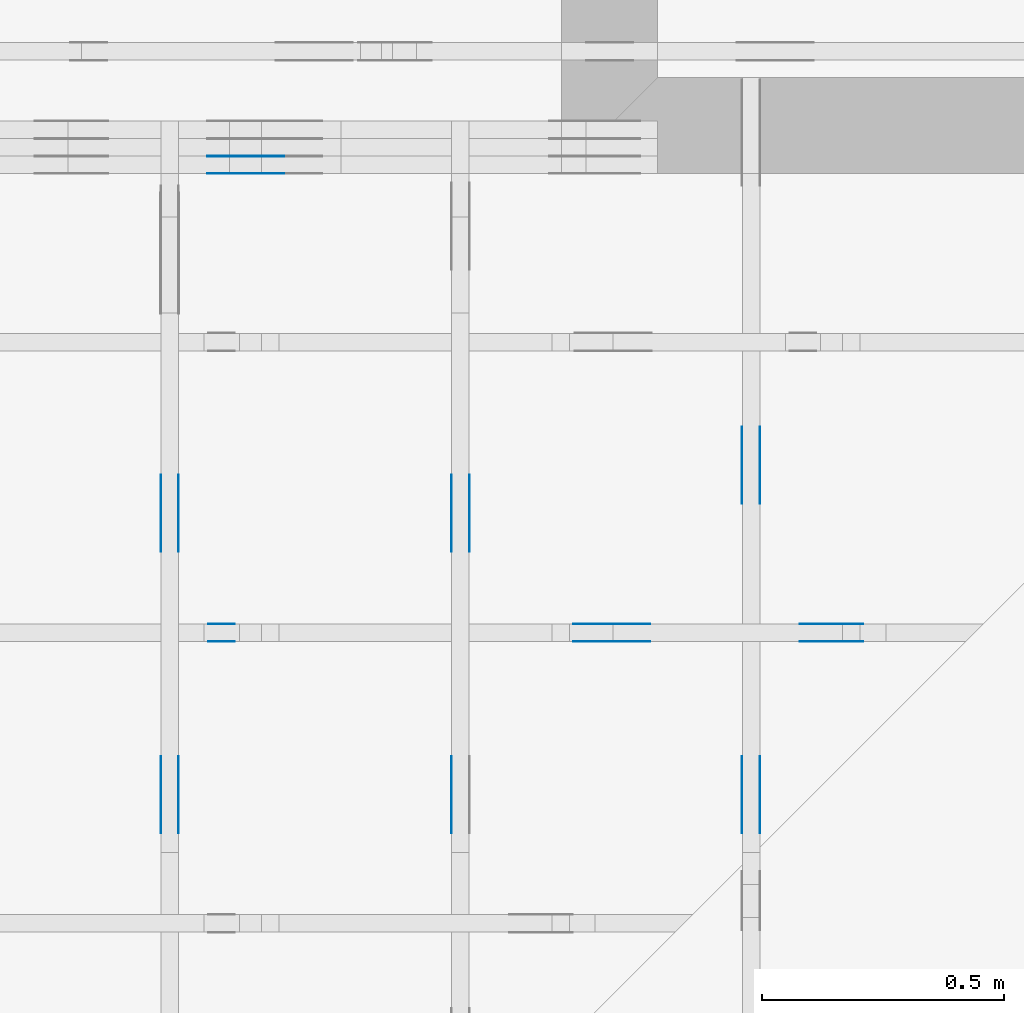
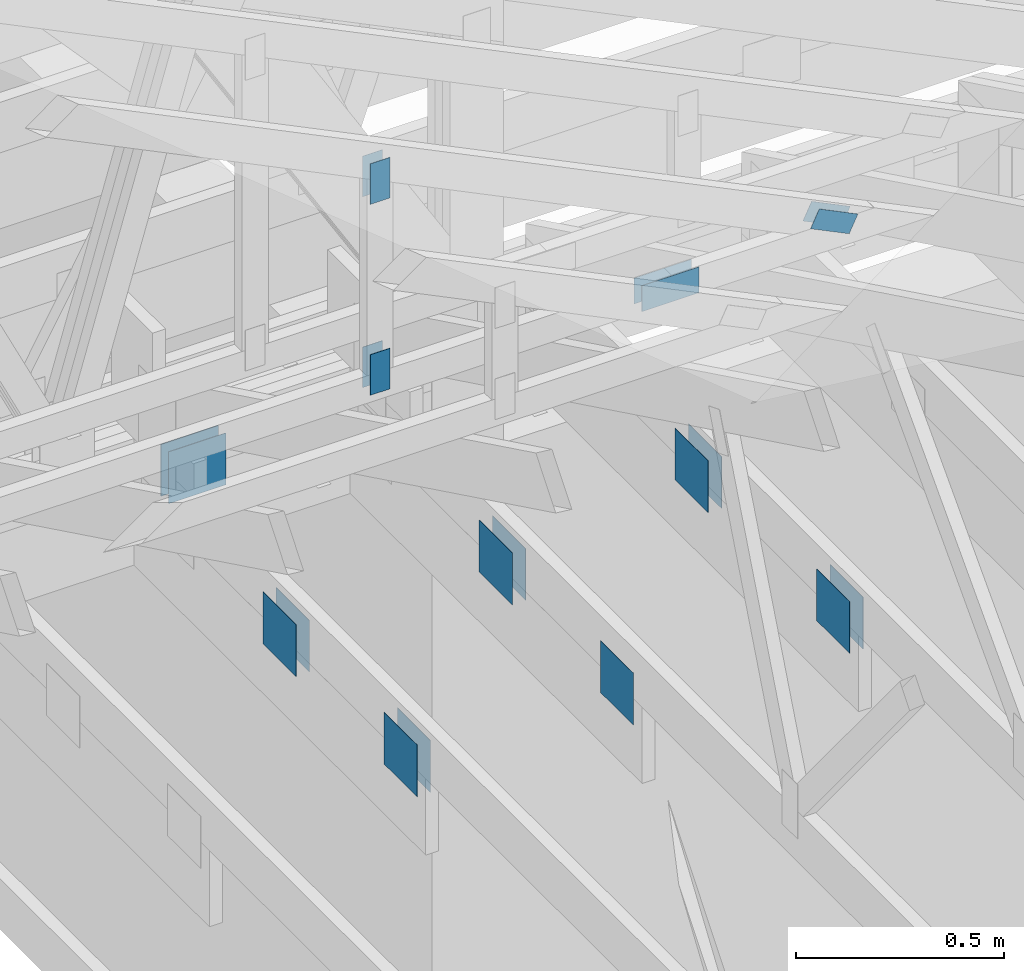
# One storey, part 126 of 159: 22 plates, 5 elements without a shape of their own.
"""IFC2X3 building model written with IfcOpenShell, lengths in millimetres."""

from ifc_helpers import new_model, si_unit, frame, origin, origin_with_axes, origin_2d, place, context, project, spatial, faceted_brep, element, aggregate, save


model = new_model("IFC2X3")

# Units and contexts
model_context = context("Model", 3, precision=1e-05, world=origin())
plan_context = context("Plan", 2, precision=1e-05, world=origin_2d())
ifc_project = project(units=[si_unit("LENGTHUNIT", "METRE", prefix="MILLI"), si_unit("AREAUNIT", "SQUARE_METRE"), si_unit("VOLUMEUNIT", "CUBIC_METRE"), si_unit("SOLIDANGLEUNIT", "STERADIAN"), si_unit("PLANEANGLEUNIT", "RADIAN"), si_unit("MASSUNIT", "GRAM"), si_unit("TIMEUNIT", "SECOND"), si_unit("THERMODYNAMICTEMPERATUREUNIT", "DEGREE_CELSIUS"), si_unit("LUMINOUSINTENSITYUNIT", "LUMEN")], contexts=[model_context, plan_context])

# Site, building, storey
site_placement = place(None, origin_with_axes())
site = spatial("IfcSite", under=ifc_project, at=site_placement, CompositionType="ELEMENT")
building_placement = place(site_placement, origin_with_axes())
building = spatial("IfcBuilding", under=site, at=building_placement, Name="Plan 1", CompositionType="ELEMENT")
storey_placement = place(building_placement, origin_with_axes())
storey = spatial("IfcBuildingStorey", under=building, at=storey_placement, Name="Etasje 1", CompositionType="ELEMENT", Elevation=0.0)

# Assembly, plates
assembly_1_placement = place(storey_placement, frame((10700.012663101485, 8801.999999990367, 0.0), z_axis=(0.0, -1.0, 6.123031769111886e-17), x_axis=(1.0, 0.0, 0.0)))
assembly_1 = element("IfcElementAssembly", 1, at=assembly_1_placement, inside=storey, Name="T8 (1)", AssemblyPlace="FACTORY", PredefinedType="TRUSS")
plate_1_placement = place(assembly_1_placement, frame((5070.5, 146.99999999999977, 0.0), z_axis=(0.0, 0.0, 1.0), x_axis=(1.0, 0.0, 0.0)))
plate_1 = element("IfcPlate", 2, at=plate_1_placement, Name="GNT100S 152x159", context=model_context, shape_type="Brep", body=[
    faceted_brep([(159.0, 152.00000000000023, 1.0), (0.0, 152.00000000000023, 1.0), (0.0, 2.2737367544323206e-13, 1.0), (159.0, 2.2737367544323206e-13, 1.0), (0.0, 152.00000000000023, 0.0), (159.0, 152.00000000000023, 1.9471241025775798e-14), (159.0, 2.2737367544323206e-13, 1.9471241025775798e-14), (0.0, 2.2737367544323206e-13, 0.0), (159.0, -2.92068615386637e-14, 1.788345410772899e-30), (159.0, -2.914563122097258e-14, 1.0), (1.1247455413666031e-32, 6.123031769111886e-17, 1.0), (0.0, 0.0, 0.0), (159.0, 152.0, 0.0), (159.0, 152.0, 1.0), (159.0, 0.0, 1.0), (159.0, 0.0, 0.0), (0.0, 152.0, 0.0), (-3.7491518045553436e-33, 152.0, 1.0), (159.0, 152.0, 1.0), (159.0, 152.0, 0.0), (0.0, 0.0, 0.0), (6.123031769111886e-17, -7.498303609110687e-33, 1.0), (1.8675246895791253e-14, 152.0, 1.0), (1.8614016578100134e-14, 152.0, -1.1397421485848245e-30)], [[[0, 1, 2, 3]], [[4, 5, 6, 7]], [[8, 9, 10, 11]], [[12, 13, 14, 15]], [[16, 17, 18, 19]], [[20, 21, 22, 23]]]),
])
plate_2_placement = place(assembly_1_placement, frame((5070.5, 146.99999999999977, -37.0), z_axis=(0.0, 0.0, 1.0), x_axis=(1.0, 0.0, 0.0)))
plate_2 = element("IfcPlate", 3, at=plate_2_placement, Name="GNT100S 152x159", context=model_context, shape_type="Brep", body=[
    faceted_brep([(159.0, 152.00000000000023, 1.0), (0.0, 152.00000000000023, 1.0), (0.0, 2.2737367544323206e-13, 1.0), (159.0, 2.2737367544323206e-13, 1.0), (0.0, 152.00000000000023, 0.0), (159.0, 152.00000000000023, 1.9471241025775798e-14), (159.0, 2.2737367544323206e-13, 1.9471241025775798e-14), (0.0, 2.2737367544323206e-13, 0.0), (159.0, -2.92068615386637e-14, 1.788345410772899e-30), (159.0, -2.914563122097258e-14, 1.0), (1.1247455413666031e-32, 6.123031769111886e-17, 1.0), (0.0, 0.0, 0.0), (159.0, 152.0, 0.0), (159.0, 152.0, 1.0), (159.0, 0.0, 1.0), (159.0, 0.0, 0.0), (0.0, 152.0, 0.0), (-3.7491518045553436e-33, 152.0, 1.0), (159.0, 152.0, 1.0), (159.0, 152.0, 0.0), (0.0, 0.0, 0.0), (6.123031769111886e-17, -7.498303609110687e-33, 1.0), (1.8675246895791253e-14, 152.0, 1.0), (1.8614016578100134e-14, 152.0, -1.1397421485848245e-30)], [[[0, 1, 2, 3]], [[4, 5, 6, 7]], [[8, 9, 10, 11]], [[12, 13, 14, 15]], [[16, 17, 18, 19]], [[20, 21, 22, 23]]]),
])
plate_3_placement = place(assembly_1_placement, frame((5070.5, 146.99999999999977, -36.0), z_axis=(0.0, 0.0, 1.0), x_axis=(1.0, 0.0, 0.0)))
plate_3 = element("IfcPlate", 4, at=plate_3_placement, Name="GNT100S 152x159", context=model_context, shape_type="Brep", body=[
    faceted_brep([(159.0, 152.00000000000023, 1.0), (0.0, 152.00000000000023, 1.0), (0.0, 2.2737367544323206e-13, 1.0), (159.0, 2.2737367544323206e-13, 1.0), (0.0, 152.00000000000023, 0.0), (159.0, 152.00000000000023, 1.9471241025775798e-14), (159.0, 2.2737367544323206e-13, 1.9471241025775798e-14), (0.0, 2.2737367544323206e-13, 0.0), (159.0, -2.92068615386637e-14, 1.788345410772899e-30), (159.0, -2.914563122097258e-14, 1.0), (1.1247455413666031e-32, 6.123031769111886e-17, 1.0), (0.0, 0.0, 0.0), (159.0, 152.0, 0.0), (159.0, 152.0, 1.0), (159.0, 0.0, 1.0), (159.0, 0.0, 0.0), (0.0, 152.0, 0.0), (-3.7491518045553436e-33, 152.0, 1.0), (159.0, 152.0, 1.0), (159.0, 152.0, 0.0), (0.0, 0.0, 0.0), (6.123031769111886e-17, -7.498303609110687e-33, 1.0), (1.8675246895791253e-14, 152.0, 1.0), (1.8614016578100134e-14, 152.0, -1.1397421485848245e-30)], [[[0, 1, 2, 3]], [[4, 5, 6, 7]], [[8, 9, 10, 11]], [[12, 13, 14, 15]], [[16, 17, 18, 19]], [[20, 21, 22, 23]]]),
])
aggregate(assembly_1, [plate_1, plate_2, plate_3])

assembly_2_placement = place(storey_placement, frame((16311.022261404749, -699.9989301294839, 1.1021457184401395e-15), z_axis=(1.0, -6.123031769111886e-17, 6.123031769111886e-17), x_axis=(6.123031769111886e-17, 1.0, 0.0)))
assembly_2 = element("IfcElementAssembly", 5, at=assembly_2_placement, inside=storey, Name="V8 (33)", AssemblyPlace="FACTORY", PredefinedType="TRUSS")
plate_4_placement = place(assembly_2_placement, frame((8139.998930119909, 147.0, -37.0), z_axis=(0.0, 0.0, 1.0), x_axis=(1.0, 0.0, 0.0)))
plate_4 = element("IfcPlate", 6, at=plate_4_placement, Name="GNT100S 152x159", context=model_context, shape_type="Brep", body=[
    faceted_brep([(159.00009331759065, 152.0, 1.0), (9.331759065389633e-05, 152.0, 1.0), (9.331759065389633e-05, 0.0, 1.0), (159.00009331759065, 0.0, 1.0), (9.331759065389633e-05, 152.0, 1.1427731443815714e-20), (159.00009331759065, 152.0, 1.9471252453507242e-14), (159.00009331759065, 0.0, 1.9471252453507242e-14), (9.331759065389633e-05, 0.0, 1.1427731443815714e-20), (159.0, 4.5396219877820443e-13, 1.788345410772899e-30), (159.0, 4.5402342909589555e-13, 1.0), (1.1247455413666031e-32, 4.832302906345592e-13, 1.0), (0.0, 4.831690603168681e-13, 0.0), (159.0, 152.00000000000045, 0.0), (159.0, 152.00000000000045, 1.0), (159.0, 4.831690603168681e-13, 1.0), (159.0, 4.831690603168681e-13, 0.0), (0.0, 152.00000000000045, 0.0), (-3.7491518045553436e-33, 152.00000000000045, 1.0), (159.0, 152.00000000000045, 1.0), (159.0, 152.00000000000045, 0.0), (5.916919012344241e-29, 4.831690603168681e-13, -3.6229483087845916e-45), (6.123031769117803e-17, 4.831690603168681e-13, 1.0), (1.867524689579131e-14, 152.00000000000045, 1.0), (1.861401657810019e-14, 152.00000000000045, -1.1397421485848278e-30)], [[[0, 1, 2, 3]], [[4, 5, 6, 7]], [[8, 9, 10, 11]], [[12, 13, 14, 15]], [[16, 17, 18, 19]], [[20, 21, 22, 23]]]),
])
plate_5_placement = place(assembly_2_placement, frame((8721.49893011991, 147.0, 0.0), z_axis=(0.0, 0.0, 1.0), x_axis=(1.0, 0.0, 0.0)))
plate_5 = element("IfcPlate", 7, at=plate_5_placement, Name="GNT100S 152x159", context=model_context, shape_type="Brep", body=[
    faceted_brep([(159.00009331759065, 152.0, 1.0), (9.331759065389633e-05, 152.0, 1.0), (9.331759065389633e-05, 0.0, 1.0), (159.00009331759065, 0.0, 1.0), (9.331759065389633e-05, 152.0, 1.1427731443815714e-20), (159.00009331759065, 152.0, 1.9471252453507242e-14), (159.00009331759065, 0.0, 1.9471252453507242e-14), (9.331759065389633e-05, 0.0, 1.1427731443815714e-20), (159.0, 4.5396219877820443e-13, 1.788345410772899e-30), (159.0, 4.5402342909589555e-13, 1.0), (1.1247455413666031e-32, 4.832302906345592e-13, 1.0), (0.0, 4.831690603168681e-13, 0.0), (159.0, 152.00000000000045, 0.0), (159.0, 152.00000000000045, 1.0), (159.0, 4.831690603168681e-13, 1.0), (159.0, 4.831690603168681e-13, 0.0), (0.0, 152.00000000000045, 0.0), (-3.7491518045553436e-33, 152.00000000000045, 1.0), (159.0, 152.00000000000045, 1.0), (159.0, 152.00000000000045, 0.0), (5.916919012344241e-29, 4.831690603168681e-13, -3.6229483087845916e-45), (6.123031769117803e-17, 4.831690603168681e-13, 1.0), (1.867524689579131e-14, 152.00000000000045, 1.0), (1.861401657810019e-14, 152.00000000000045, -1.1397421485848278e-30)], [[[0, 1, 2, 3]], [[4, 5, 6, 7]], [[8, 9, 10, 11]], [[12, 13, 14, 15]], [[16, 17, 18, 19]], [[20, 21, 22, 23]]]),
])
plate_6_placement = place(assembly_2_placement, frame((8721.49893011991, 147.0, -37.0), z_axis=(0.0, 0.0, 1.0), x_axis=(1.0, 0.0, 0.0)))
plate_6 = element("IfcPlate", 8, at=plate_6_placement, Name="GNT100S 152x159", context=model_context, shape_type="Brep", body=[
    faceted_brep([(159.00009331759065, 152.0, 1.0), (9.331759065389633e-05, 152.0, 1.0), (9.331759065389633e-05, 0.0, 1.0), (159.00009331759065, 0.0, 1.0), (9.331759065389633e-05, 152.0, 1.1427731443815714e-20), (159.00009331759065, 152.0, 1.9471252453507242e-14), (159.00009331759065, 0.0, 1.9471252453507242e-14), (9.331759065389633e-05, 0.0, 1.1427731443815714e-20), (159.0, 4.5396219877820443e-13, 1.788345410772899e-30), (159.0, 4.5402342909589555e-13, 1.0), (1.1247455413666031e-32, 4.832302906345592e-13, 1.0), (0.0, 4.831690603168681e-13, 0.0), (159.0, 152.00000000000045, 0.0), (159.0, 152.00000000000045, 1.0), (159.0, 4.831690603168681e-13, 1.0), (159.0, 4.831690603168681e-13, 0.0), (0.0, 152.00000000000045, 0.0), (-3.7491518045553436e-33, 152.00000000000045, 1.0), (159.0, 152.00000000000045, 1.0), (159.0, 152.00000000000045, 0.0), (5.916919012344241e-29, 4.831690603168681e-13, -3.6229483087845916e-45), (6.123031769117803e-17, 4.831690603168681e-13, 1.0), (1.867524689579131e-14, 152.00000000000045, 1.0), (1.861401657810019e-14, 152.00000000000045, -1.1397421485848278e-30)], [[[0, 1, 2, 3]], [[4, 5, 6, 7]], [[8, 9, 10, 11]], [[12, 13, 14, 15]], [[16, 17, 18, 19]], [[20, 21, 22, 23]]]),
])
aggregate(assembly_2, [plate_4, plate_5, plate_6])

assembly_3_placement = place(storey_placement, frame((16875.02226140475, -699.9989301294827, 1.1021457184401395e-15), z_axis=(-1.0, 1.836909530733566e-16, 6.123031769111886e-17), x_axis=(-1.836909530733566e-16, -1.0, 0.0)))
assembly_3 = element("IfcElementAssembly", 9, at=assembly_3_placement, inside=storey, Name="V7 (32)", AssemblyPlace="FACTORY", PredefinedType="TRUSS")
plate_7_placement = place(assembly_3_placement, frame((-8140.0, 299.0, 0.0), z_axis=(0.0, 0.0, 1.0), x_axis=(-1.0, 1.2246063538223773e-16, 0.0)))
plate_7 = element("IfcPlate", 10, at=plate_7_placement, Name="GNT100S 152x159", context=model_context, shape_type="Brep", body=[
    faceted_brep([(159.0, 151.99999999999997, 1.0), (0.0, 151.99999999999997, 1.0), (0.0, 0.0, 1.0), (159.0, 0.0, 1.0), (0.0, 151.99999999999997, 0.0), (159.0, 151.99999999999997, 1.9471241025775798e-14), (159.0, 0.0, 1.9471241025775798e-14), (0.0, 0.0, 0.0), (159.0, -2.92068615386637e-14, 1.788345410772899e-30), (159.0, -2.914563122097258e-14, 1.0), (1.1247455413666031e-32, 6.123031769111886e-17, 1.0), (0.0, 0.0, 0.0), (159.0, 152.0, 0.0), (159.0, 152.0, 1.0), (159.0, 0.0, 1.0), (159.0, 0.0, 0.0), (0.0, 151.99999999999997, 0.0), (0.0, 151.99999999999997, 1.0), (159.0, 152.0, 1.0), (159.0, 152.0, 0.0), (0.0, 0.0, 0.0), (6.123031769111886e-17, -7.498303609110687e-33, 1.0), (1.867524689579125e-14, 151.99999999999997, 1.0), (1.861401657810013e-14, 151.99999999999997, -1.1397421485848243e-30)], [[[0, 1, 2, 3]], [[4, 5, 6, 7]], [[8, 9, 10, 11]], [[12, 13, 14, 15]], [[16, 17, 18, 19]], [[20, 21, 22, 23]]]),
])
plate_8_placement = place(assembly_3_placement, frame((-8140.0, 299.0, -37.0), z_axis=(0.0, 0.0, 1.0), x_axis=(-1.0, 1.2246063538223773e-16, 0.0)))
plate_8 = element("IfcPlate", 11, at=plate_8_placement, Name="GNT100S 152x159", context=model_context, shape_type="Brep", body=[
    faceted_brep([(159.0, 151.99999999999997, 1.0), (0.0, 151.99999999999997, 1.0), (0.0, 0.0, 1.0), (159.0, 0.0, 1.0), (0.0, 151.99999999999997, 0.0), (159.0, 151.99999999999997, 1.9471241025775798e-14), (159.0, 0.0, 1.9471241025775798e-14), (0.0, 0.0, 0.0), (159.0, -2.92068615386637e-14, 1.788345410772899e-30), (159.0, -2.914563122097258e-14, 1.0), (1.1247455413666031e-32, 6.123031769111886e-17, 1.0), (0.0, 0.0, 0.0), (159.0, 152.0, 0.0), (159.0, 152.0, 1.0), (159.0, 0.0, 1.0), (159.0, 0.0, 0.0), (0.0, 151.99999999999997, 0.0), (0.0, 151.99999999999997, 1.0), (159.0, 152.0, 1.0), (159.0, 152.0, 0.0), (0.0, 0.0, 0.0), (6.123031769111886e-17, -7.498303609110687e-33, 1.0), (1.867524689579125e-14, 151.99999999999997, 1.0), (1.861401657810013e-14, 151.99999999999997, -1.1397421485848243e-30)], [[[0, 1, 2, 3]], [[4, 5, 6, 7]], [[8, 9, 10, 11]], [[12, 13, 14, 15]], [[16, 17, 18, 19]], [[20, 21, 22, 23]]]),
])
plate_9_placement = place(assembly_3_placement, frame((-8979.49946198694, 147.0, 0.0), z_axis=(0.0, 0.0, 1.0), x_axis=(1.0, 0.0, 0.0)))
plate_9 = element("IfcPlate", 12, at=plate_9_placement, Name="GNT100S 152x159", context=model_context, shape_type="Brep", body=[
    faceted_brep([(159.00043854943942, 152.0, 1.0), (0.00043854943942278624, 152.0, 1.0), (0.00043854943942278624, 0.0, 1.0), (159.00043854943942, 0.0, 1.0), (0.00043854943942278624, 152.0, 5.3705042998238576e-20), (159.00043854943942, 152.0, 1.9471294730818797e-14), (159.00043854943942, 0.0, 1.9471294730818797e-14), (0.00043854943942278624, 0.0, 5.3705042998238576e-20), (159.0, 5.6058266752548325e-14, 1.788345410772899e-30), (159.0, 5.6119497070239444e-14, 1.0), (1.1247455413666031e-32, 8.532635860890314e-14, 1.0), (0.0, 8.526512829121202e-14, 0.0), (159.0, 152.0000000000001, 0.0), (159.0, 152.0000000000001, 1.0), (159.0, 8.526512829121202e-14, 1.0), (159.0, 8.526512829121202e-14, 0.0), (4.861730685829017e-63, 152.0000000000001, 0.0), (-3.7491518045553436e-33, 152.0000000000001, 1.0), (159.0, 152.0000000000001, 1.0), (159.0, 152.0000000000001, 0.0), (1.0441621786489838e-29, 8.526512829121202e-14, -6.393438191972809e-46), (6.12303176911293e-17, 8.526512829121202e-14, 1.0), (1.8675246895791266e-14, 152.0000000000001, 1.0), (1.8614016578100147e-14, 152.0000000000001, -1.1397421485848253e-30)], [[[0, 1, 2, 3]], [[4, 5, 6, 7]], [[8, 9, 10, 11]], [[12, 13, 14, 15]], [[16, 17, 18, 19]], [[20, 21, 22, 23]]]),
])
plate_10_placement = place(assembly_3_placement, frame((-8979.49946198694, 147.0, -37.0), z_axis=(0.0, 0.0, 1.0), x_axis=(1.0, 0.0, 0.0)))
plate_10 = element("IfcPlate", 13, at=plate_10_placement, Name="GNT100S 152x159", context=model_context, shape_type="Brep", body=[
    faceted_brep([(159.00043854943942, 152.0, 1.0), (0.00043854943942278624, 152.0, 1.0), (0.00043854943942278624, 0.0, 1.0), (159.00043854943942, 0.0, 1.0), (0.00043854943942278624, 152.0, 5.3705042998238576e-20), (159.00043854943942, 152.0, 1.9471294730818797e-14), (159.00043854943942, 0.0, 1.9471294730818797e-14), (0.00043854943942278624, 0.0, 5.3705042998238576e-20), (159.0, 5.6058266752548325e-14, 1.788345410772899e-30), (159.0, 5.6119497070239444e-14, 1.0), (1.1247455413666031e-32, 8.532635860890314e-14, 1.0), (0.0, 8.526512829121202e-14, 0.0), (159.0, 152.0000000000001, 0.0), (159.0, 152.0000000000001, 1.0), (159.0, 8.526512829121202e-14, 1.0), (159.0, 8.526512829121202e-14, 0.0), (4.861730685829017e-63, 152.0000000000001, 0.0), (-3.7491518045553436e-33, 152.0000000000001, 1.0), (159.0, 152.0000000000001, 1.0), (159.0, 152.0000000000001, 0.0), (1.0441621786489838e-29, 8.526512829121202e-14, -6.393438191972809e-46), (6.12303176911293e-17, 8.526512829121202e-14, 1.0), (1.8675246895791266e-14, 152.0000000000001, 1.0), (1.8614016578100147e-14, 152.0000000000001, -1.1397421485848253e-30)], [[[0, 1, 2, 3]], [[4, 5, 6, 7]], [[8, 9, 10, 11]], [[12, 13, 14, 15]], [[16, 17, 18, 19]], [[20, 21, 22, 23]]]),
])
aggregate(assembly_3, [plate_7, plate_8, plate_9, plate_10])

assembly_4_placement = place(storey_placement, frame((11846.012601162385, 7836.000061939094, 1020.3543282828622), z_axis=(0.0, -1.0, 6.123031769111886e-17), x_axis=(1.0, 0.0, 0.0)))
assembly_4 = element("IfcElementAssembly", 14, at=assembly_4_placement, inside=storey, Name="Tr2 (1)", AssemblyPlace="FACTORY", PredefinedType="TRUSS")
plate_11_placement = place(assembly_4_placement, frame((5278.826338056933, 87.8545820693189, 0.0), z_axis=(0.0, 0.0, 1.0), x_axis=(-0.8987940462991675, 0.4383711467890765, 0.0)))
plate_11 = element("IfcPlate", 15, at=plate_11_placement, Name="GNT100S 55x119", context=model_context, shape_type="Brep", body=[
    faceted_brep([(119.00013957883584, 55.00004556233944, 1.0), (9.423495885130251e-05, 55.00004556233944, 1.0), (0.00015009581420599716, 7.134755560400663e-05, 1.0), (119.00019711194454, 7.134755560400663e-05, 1.0), (9.423495885130251e-05, 55.00004556233944, 1.1540072936149532e-20), (119.00013957883584, 55.00004556233944, 1.4572832703399214e-14), (119.00019711194454, 9.233737455360824e-05, 1.457283974894026e-14), (0.00015009581420599716, 9.233737455360824e-05, 1.8380828775880715e-20), (119.0, -2.1859223415729434e-14, 1.3384471942262577e-30), (119.0, -2.1797993098038315e-14, 1.0), (1.1247455413666031e-32, 6.123031769111886e-17, 1.0), (0.0, 0.0, 0.0), (119.0, 55.0, 0.0), (119.0, 55.0, 1.0), (119.0, 0.0, 1.0), (119.0, 0.0, 0.0), (0.0, 55.0, 0.0), (-3.7491518045553436e-33, 55.0, 1.0), (119.0, 54.99999999999999, 1.0), (119.0, 54.99999999999999, -3.944304526105059e-31), (0.0, 0.0, 0.0), (6.123031769111886e-17, -7.498303609110687e-33, 1.0), (6.796565263714194e-15, 55.0, 1.0), (6.735334946023075e-15, 55.0, -4.124066985010878e-31)], [[[0, 1, 2, 3]], [[4, 5, 6, 7]], [[8, 9, 10, 11]], [[12, 13, 14, 15]], [[16, 17, 18, 19]], [[20, 21, 22, 23]]]),
])
plate_12_placement = place(assembly_4_placement, frame((5278.826338056933, 87.8545820693189, -37.0), z_axis=(0.0, 0.0, 1.0), x_axis=(-0.8987940462991675, 0.4383711467890765, 0.0)))
plate_12 = element("IfcPlate", 16, at=plate_12_placement, Name="GNT100S 55x119", context=model_context, shape_type="Brep", body=[
    faceted_brep([(119.00013957883584, 55.00004556233944, 1.0), (9.423495885130251e-05, 55.00004556233944, 1.0), (0.00015009581420599716, 7.134755560400663e-05, 1.0), (119.00019711194454, 7.134755560400663e-05, 1.0), (9.423495885130251e-05, 55.00004556233944, 1.1540072936149532e-20), (119.00013957883584, 55.00004556233944, 1.4572832703399214e-14), (119.00019711194454, 9.233737455360824e-05, 1.457283974894026e-14), (0.00015009581420599716, 9.233737455360824e-05, 1.8380828775880715e-20), (119.0, -2.1859223415729434e-14, 1.3384471942262577e-30), (119.0, -2.1797993098038315e-14, 1.0), (1.1247455413666031e-32, 6.123031769111886e-17, 1.0), (0.0, 0.0, 0.0), (119.0, 55.0, 0.0), (119.0, 55.0, 1.0), (119.0, 0.0, 1.0), (119.0, 0.0, 0.0), (0.0, 55.0, 0.0), (-3.7491518045553436e-33, 55.0, 1.0), (119.0, 54.99999999999999, 1.0), (119.0, 54.99999999999999, -3.944304526105059e-31), (0.0, 0.0, 0.0), (6.123031769111886e-17, -7.498303609110687e-33, 1.0), (6.796565263714194e-15, 55.0, 1.0), (6.735334946023075e-15, 55.0, -4.124066985010878e-31)], [[[0, 1, 2, 3]], [[4, 5, 6, 7]], [[8, 9, 10, 11]], [[12, 13, 14, 15]], [[16, 17, 18, 19]], [[20, 21, 22, 23]]]),
])
plate_13_placement = place(assembly_4_placement, frame((3926.5, 708.4014892578125, 0.0), z_axis=(0.0, 0.0, 1.0), x_axis=(6.123031769111886e-17, -1.0, 0.0)))
plate_13 = element("IfcPlate", 17, at=plate_13_placement, Name="GNT100S 55x119", context=model_context, shape_type="Brep", body=[
    faceted_brep([(119.0, 55.0, 1.0), (0.0, 55.0, 1.0), (0.0, 0.0, 1.0), (119.0, 0.0, 1.0), (0.0, 55.0, 0.0), (119.0, 55.0, 1.457281561048629e-14), (119.0, 0.0, 1.457281561048629e-14), (0.0, 0.0, 0.0), (119.00000658339877, 6.193909755526468e-05, 1.3384475843434453e-30), (119.00000658339877, 6.193909755532591e-05, 1.0), (6.583398771908833e-06, 6.193909757718513e-05, 1.0), (6.583398771908833e-06, 6.19390975771239e-05, 0.0), (119.00000658339877, 55.00006193909758, 0.0), (119.00000658339877, 55.00006193909758, 1.0), (119.00000658339877, 6.19390975771239e-05, 1.0), (119.00000658339877, 6.19390975771239e-05, 0.0), (6.583398771908833e-06, 55.00006193909758, 0.0), (6.583398771908833e-06, 55.00006193909758, 1.0), (119.00000658339877, 55.00006193909757, 1.0), (119.00000658339877, 55.00006193909757, -3.944304526105059e-31), (6.58339877190884e-06, 6.19390975771239e-05, -4.70197740328915e-37), (6.583398771970071e-06, 6.19390975771239e-05, 1.0), (6.583398778705406e-06, 55.00006193909758, 1.0), (6.583398778644175e-06, 55.00006193909758, -4.1240714665830905e-31)], [[[0, 1, 2, 3]], [[4, 5, 6, 7]], [[8, 9, 10, 11]], [[12, 13, 14, 15]], [[16, 17, 18, 19]], [[20, 21, 22, 23]]]),
])
plate_14_placement = place(assembly_4_placement, frame((3926.5, 708.4014892578125, -37.0), z_axis=(0.0, 0.0, 1.0), x_axis=(6.123031769111886e-17, -1.0, 0.0)))
plate_14 = element("IfcPlate", 18, at=plate_14_placement, Name="GNT100S 55x119", context=model_context, shape_type="Brep", body=[
    faceted_brep([(119.0, 55.0, 1.0), (0.0, 55.0, 1.0), (0.0, 0.0, 1.0), (119.0, 0.0, 1.0), (0.0, 55.0, 0.0), (119.0, 55.0, 1.457281561048629e-14), (119.0, 0.0, 1.457281561048629e-14), (0.0, 0.0, 0.0), (119.00000658339877, 6.193909755526468e-05, 1.3384475843434453e-30), (119.00000658339877, 6.193909755532591e-05, 1.0), (6.583398771908833e-06, 6.193909757718513e-05, 1.0), (6.583398771908833e-06, 6.19390975771239e-05, 0.0), (119.00000658339877, 55.00006193909758, 0.0), (119.00000658339877, 55.00006193909758, 1.0), (119.00000658339877, 6.19390975771239e-05, 1.0), (119.00000658339877, 6.19390975771239e-05, 0.0), (6.583398771908833e-06, 55.00006193909758, 0.0), (6.583398771908833e-06, 55.00006193909758, 1.0), (119.00000658339877, 55.00006193909757, 1.0), (119.00000658339877, 55.00006193909757, -3.944304526105059e-31), (6.58339877190884e-06, 6.19390975771239e-05, -4.70197740328915e-37), (6.583398771970071e-06, 6.19390975771239e-05, 1.0), (6.583398778705406e-06, 55.00006193909758, 1.0), (6.583398778644175e-06, 55.00006193909758, -4.1240714665830905e-31)], [[[0, 1, 2, 3]], [[4, 5, 6, 7]], [[8, 9, 10, 11]], [[12, 13, 14, 15]], [[16, 17, 18, 19]], [[20, 21, 22, 23]]]),
])
plate_15_placement = place(assembly_4_placement, frame((4838.491242971271, 87.24628448486328, 0.0), z_axis=(0.0, 0.0, 1.0), x_axis=(-1.0, 1.2246063538223773e-16, 0.0)))
plate_15 = element("IfcPlate", 19, at=plate_15_placement, Name="GNT100S 76x159", context=model_context, shape_type="Brep", body=[
    faceted_brep([(159.00003203377128, 76.00000381469727, 1.0), (3.2033771276474e-05, 76.00000381469727, 1.0), (3.2033771276474e-05, 0.0, 1.0), (159.00003203377128, 0.0, 1.0), (3.2033771276474e-05, 76.00000381469727, 3.922875984206282e-21), (159.00003203377128, 76.00000381469727, 1.9471244948651783e-14), (159.00003203377128, 2.842170943040401e-14, 1.9471244948651783e-14), (3.2033771276474e-05, 2.842170943040401e-14, 3.922875984206282e-21), (159.0, 3.7946652887619313e-06, 2.6584805794835192e-30), (159.0, 3.7946652888231616e-06, 1.0), (1.1247459087085877e-32, 3.794665318030023e-06, 1.0), (0.0, 3.794665317968793e-06, 0.0), (159.0, 76.00000379466533, 0.0), (159.0, 76.00000379466533, 1.0), (159.0, 3.7946653321796475e-06, 1.0), (159.0, 3.7946653321796475e-06, 0.0), (0.0, 76.00000379466532, 0.0), (0.0, 76.00000379466532, 1.0), (159.0, 76.00000379466535, 1.0), (159.0, 76.00000379466535, 7.888609052210118e-31), (4.646971259013995e-22, 3.794665317968793e-06, -2.845355264909255e-38), (6.123078238824477e-17, 3.794665317968793e-06, 1.0), (9.368239071438311e-15, 76.00000379466532, 1.0), (9.307008753747193e-15, 76.00000379466532, -5.698711027459649e-31)], [[[0, 1, 2, 3]], [[4, 5, 6, 7]], [[8, 9, 10, 11]], [[12, 13, 14, 15]], [[16, 17, 18, 19]], [[20, 21, 22, 23]]]),
])
plate_16_placement = place(assembly_4_placement, frame((4838.491242971271, 87.24628448486328, -37.0), z_axis=(0.0, 0.0, 1.0), x_axis=(-1.0, 1.2246063538223773e-16, 0.0)))
plate_16 = element("IfcPlate", 20, at=plate_16_placement, Name="GNT100S 76x159", context=model_context, shape_type="Brep", body=[
    faceted_brep([(159.00003203377128, 76.00000381469727, 1.0), (3.2033771276474e-05, 76.00000381469727, 1.0), (3.2033771276474e-05, 0.0, 1.0), (159.00003203377128, 0.0, 1.0), (3.2033771276474e-05, 76.00000381469727, 3.922875984206282e-21), (159.00003203377128, 76.00000381469727, 1.9471244948651783e-14), (159.00003203377128, 2.842170943040401e-14, 1.9471244948651783e-14), (3.2033771276474e-05, 2.842170943040401e-14, 3.922875984206282e-21), (159.0, 3.7946652887619313e-06, 2.6584805794835192e-30), (159.0, 3.7946652888231616e-06, 1.0), (1.1247459087085877e-32, 3.794665318030023e-06, 1.0), (0.0, 3.794665317968793e-06, 0.0), (159.0, 76.00000379466533, 0.0), (159.0, 76.00000379466533, 1.0), (159.0, 3.7946653321796475e-06, 1.0), (159.0, 3.7946653321796475e-06, 0.0), (0.0, 76.00000379466532, 0.0), (0.0, 76.00000379466532, 1.0), (159.0, 76.00000379466535, 1.0), (159.0, 76.00000379466535, 7.888609052210118e-31), (4.646971259013995e-22, 3.794665317968793e-06, -2.845355264909255e-38), (6.123078238824477e-17, 3.794665317968793e-06, 1.0), (9.368239071438311e-15, 76.00000379466532, 1.0), (9.307008753747193e-15, 76.00000379466532, -5.698711027459649e-31)], [[[0, 1, 2, 3]], [[4, 5, 6, 7]], [[8, 9, 10, 11]], [[12, 13, 14, 15]], [[16, 17, 18, 19]], [[20, 21, 22, 23]]]),
])
plate_17_placement = place(assembly_4_placement, frame((3981.5000619390976, 29.720829010009762, 0.0), z_axis=(0.0, 0.0, 1.0), x_axis=(6.123031769111886e-17, 1.0, 0.0)))
plate_17 = element("IfcPlate", 21, at=plate_17_placement, Name="GNT100S 55x119", context=model_context, shape_type="Brep", body=[
    faceted_brep([(118.99999618530272, 55.00006193909758, 1.0), (0.0, 55.00006193909758, 1.0), (3.552713678800501e-15, 6.19390975771239e-05, 1.0), (118.99999618530275, 6.19390975771239e-05, 1.0), (0.0, 55.00006193909758, 0.0), (118.99999618530272, 55.00006193909758, 1.4572815143336035e-14), (118.99999618530275, 6.19390975771239e-05, 1.4572815143336042e-14), (3.552713678800501e-15, 6.19390975771239e-05, 4.350675744370766e-31), (119.00000002011264, -2.1859223419423944e-14, 1.3384471944524737e-30), (119.00000002011264, -2.1797993101732825e-14, 1.0), (2.0112626231139075e-08, 6.123031399661138e-17, 1.0), (2.0112626231139075e-08, -3.6945074812061286e-24, 2.262158667864666e-40), (119.00000002011264, 55.0, 1.5777218104420236e-30), (119.00000002011264, 55.0, 1.0), (119.00000002011264, 0.0, 1.0), (119.00000002011264, 0.0, 0.0), (2.0112626231139075e-08, 55.0, 0.0), (2.0112626231139075e-08, 55.0, 1.0), (119.00000002011261, 54.99999999999999, 1.0), (119.00000002011261, 54.99999999999999, -3.944304526105059e-31), (2.0112626231139075e-08, 0.0, 0.0), (2.0112626292369392e-08, -7.498303609110687e-33, 1.0), (2.011263302770434e-08, 55.0, 1.0), (2.011263296647402e-08, 55.0, -4.124066985010878e-31)], [[[0, 1, 2, 3]], [[4, 5, 6, 7]], [[8, 9, 10, 11]], [[12, 13, 14, 15]], [[16, 17, 18, 19]], [[20, 21, 22, 23]]]),
])
plate_18_placement = place(assembly_4_placement, frame((3981.5000619390976, 29.720829010009762, -37.0), z_axis=(0.0, 0.0, 1.0), x_axis=(6.123031769111886e-17, 1.0, 0.0)))
plate_18 = element("IfcPlate", 22, at=plate_18_placement, Name="GNT100S 55x119", context=model_context, shape_type="Brep", body=[
    faceted_brep([(118.99999618530272, 55.00006193909758, 1.0), (0.0, 55.00006193909758, 1.0), (3.552713678800501e-15, 6.19390975771239e-05, 1.0), (118.99999618530275, 6.19390975771239e-05, 1.0), (0.0, 55.00006193909758, 0.0), (118.99999618530272, 55.00006193909758, 1.4572815143336035e-14), (118.99999618530275, 6.19390975771239e-05, 1.4572815143336042e-14), (3.552713678800501e-15, 6.19390975771239e-05, 4.350675744370766e-31), (119.00000002011264, -2.1859223419423944e-14, 1.3384471944524737e-30), (119.00000002011264, -2.1797993101732825e-14, 1.0), (2.0112626231139075e-08, 6.123031399661138e-17, 1.0), (2.0112626231139075e-08, -3.6945074812061286e-24, 2.262158667864666e-40), (119.00000002011264, 55.0, 1.5777218104420236e-30), (119.00000002011264, 55.0, 1.0), (119.00000002011264, 0.0, 1.0), (119.00000002011264, 0.0, 0.0), (2.0112626231139075e-08, 55.0, 0.0), (2.0112626231139075e-08, 55.0, 1.0), (119.00000002011261, 54.99999999999999, 1.0), (119.00000002011261, 54.99999999999999, -3.944304526105059e-31), (2.0112626231139075e-08, 0.0, 0.0), (2.0112626292369392e-08, -7.498303609110687e-33, 1.0), (2.011263302770434e-08, 55.0, 1.0), (2.011263296647402e-08, 55.0, -4.124066985010878e-31)], [[[0, 1, 2, 3]], [[4, 5, 6, 7]], [[8, 9, 10, 11]], [[12, 13, 14, 15]], [[16, 17, 18, 19]], [[20, 21, 22, 23]]]),
])
aggregate(assembly_4, [plate_11, plate_12, plate_13, plate_14, plate_15, plate_16, plate_17, plate_18])

assembly_5_placement = place(storey_placement, frame((15675.02226140475, -699.9989301294845, 1.1021457184401395e-15), z_axis=(-1.0, 1.836909530733566e-16, 6.123031769111886e-17), x_axis=(-1.836909530733566e-16, -1.0, 0.0)))
assembly_5 = element("IfcElementAssembly", 23, at=assembly_5_placement, inside=storey, Name="T7 (111)", AssemblyPlace="FACTORY", PredefinedType="TRUSS")
plate_19_placement = place(assembly_5_placement, frame((-8880.4990234375, 147.0, 0.0), z_axis=(0.0, 0.0, 1.0), x_axis=(1.0, 0.0, 0.0)))
plate_19 = element("IfcPlate", 24, at=plate_19_placement, Name="GNT100S 152x159", context=model_context, shape_type="Brep", body=[
    faceted_brep([(159.0, 152.0, 1.0), (0.0, 152.0, 1.0), (0.0, 0.0, 1.0), (159.0, 0.0, 1.0), (0.0, 152.0, 0.0), (159.0, 152.0, 1.9471241025775798e-14), (159.0, 0.0, 1.9471241025775798e-14), (0.0, 0.0, 0.0), (159.00009331759065, -2.9206878680260863e-14, 1.7883464603583392e-30), (159.00009331759065, -2.9145648362569744e-14, 1.0), (9.331759065389633e-05, 6.121317609395314e-17, 1.0), (9.331759065389633e-05, -1.714159716572357e-20, 1.0495854401904369e-36), (159.00009331759065, 152.0, 0.0), (159.00009331759065, 152.0, 1.0), (159.00009331759065, 0.0, 1.0), (159.00009331759065, 0.0, 0.0), (9.331759065389633e-05, 152.0, 0.0), (9.331759065389633e-05, 152.0, 1.0), (159.00009331759065, 152.0, 1.0), (159.00009331759065, 152.0, 0.0), (9.331759065389633e-05, 0.0, 0.0), (9.331759065395756e-05, -7.498303609110687e-33, 1.0), (9.331759067257158e-05, 152.0, 1.0), (9.331759067251035e-05, 152.0, -1.1397420192804459e-30)], [[[0, 1, 2, 3]], [[4, 5, 6, 7]], [[8, 9, 10, 11]], [[12, 13, 14, 15]], [[16, 17, 18, 19]], [[20, 21, 22, 23]]]),
])
plate_20_placement = place(assembly_5_placement, frame((-8880.4990234375, 147.0, -37.0), z_axis=(0.0, 0.0, 1.0), x_axis=(1.0, 0.0, 0.0)))
plate_20 = element("IfcPlate", 25, at=plate_20_placement, Name="GNT100S 152x159", context=model_context, shape_type="Brep", body=[
    faceted_brep([(159.0, 152.0, 1.0), (0.0, 152.0, 1.0), (0.0, 0.0, 1.0), (159.0, 0.0, 1.0), (0.0, 152.0, 0.0), (159.0, 152.0, 1.9471241025775798e-14), (159.0, 0.0, 1.9471241025775798e-14), (0.0, 0.0, 0.0), (159.00009331759065, -2.9206878680260863e-14, 1.7883464603583392e-30), (159.00009331759065, -2.9145648362569744e-14, 1.0), (9.331759065389633e-05, 6.121317609395314e-17, 1.0), (9.331759065389633e-05, -1.714159716572357e-20, 1.0495854401904369e-36), (159.00009331759065, 152.0, 0.0), (159.00009331759065, 152.0, 1.0), (159.00009331759065, 0.0, 1.0), (159.00009331759065, 0.0, 0.0), (9.331759065389633e-05, 152.0, 0.0), (9.331759065389633e-05, 152.0, 1.0), (159.00009331759065, 152.0, 1.0), (159.00009331759065, 152.0, 0.0), (9.331759065389633e-05, 0.0, 0.0), (9.331759065395756e-05, -7.498303609110687e-33, 1.0), (9.331759067257158e-05, 152.0, 1.0), (9.331759067251035e-05, 152.0, -1.1397420192804459e-30)], [[[0, 1, 2, 3]], [[4, 5, 6, 7]], [[8, 9, 10, 11]], [[12, 13, 14, 15]], [[16, 17, 18, 19]], [[20, 21, 22, 23]]]),
])
plate_21_placement = place(assembly_5_placement, frame((-8139.998930119909, 299.0, 0.0), z_axis=(0.0, 0.0, 1.0), x_axis=(-1.0, 1.2246063538223773e-16, 0.0)))
plate_21 = element("IfcPlate", 26, at=plate_21_placement, Name="GNT100S 152x159", context=model_context, shape_type="Brep", body=[
    faceted_brep([(159.00009331759065, 151.99999999999997, 1.0), (9.331759065389633e-05, 151.99999999999997, 1.0), (9.331759065389633e-05, 0.0, 1.0), (159.00009331759065, 0.0, 1.0), (9.331759065389633e-05, 151.99999999999997, 1.1427731443815714e-20), (159.00009331759065, 151.99999999999997, 1.9471252453507242e-14), (159.00009331759065, 0.0, 1.9471252453507242e-14), (9.331759065389633e-05, 0.0, 1.1427731443815714e-20), (159.0, -2.92068615386637e-14, 1.788345410772899e-30), (159.0, -2.914563122097258e-14, 1.0), (1.1247455413666031e-32, 6.123031769111886e-17, 1.0), (0.0, 0.0, 0.0), (159.0, 152.0, 0.0), (159.0, 152.0, 1.0), (159.0, 0.0, 1.0), (159.0, 0.0, 0.0), (0.0, 151.99999999999997, 0.0), (0.0, 151.99999999999997, 1.0), (159.0, 152.0, 1.0), (159.0, 152.0, 0.0), (0.0, 0.0, 0.0), (6.123031769111886e-17, -7.498303609110687e-33, 1.0), (1.867524689579125e-14, 151.99999999999997, 1.0), (1.861401657810013e-14, 151.99999999999997, -1.1397421485848243e-30)], [[[0, 1, 2, 3]], [[4, 5, 6, 7]], [[8, 9, 10, 11]], [[12, 13, 14, 15]], [[16, 17, 18, 19]], [[20, 21, 22, 23]]]),
])
plate_22_placement = place(assembly_5_placement, frame((-8139.998930119909, 299.0, -37.0), z_axis=(0.0, 0.0, 1.0), x_axis=(-1.0, 1.2246063538223773e-16, 0.0)))
plate_22 = element("IfcPlate", 27, at=plate_22_placement, Name="GNT100S 152x159", context=model_context, shape_type="Brep", body=[
    faceted_brep([(159.00009331759065, 151.99999999999997, 1.0), (9.331759065389633e-05, 151.99999999999997, 1.0), (9.331759065389633e-05, 0.0, 1.0), (159.00009331759065, 0.0, 1.0), (9.331759065389633e-05, 151.99999999999997, 1.1427731443815714e-20), (159.00009331759065, 151.99999999999997, 1.9471252453507242e-14), (159.00009331759065, 0.0, 1.9471252453507242e-14), (9.331759065389633e-05, 0.0, 1.1427731443815714e-20), (159.0, -2.92068615386637e-14, 1.788345410772899e-30), (159.0, -2.914563122097258e-14, 1.0), (1.1247455413666031e-32, 6.123031769111886e-17, 1.0), (0.0, 0.0, 0.0), (159.0, 152.0, 0.0), (159.0, 152.0, 1.0), (159.0, 0.0, 1.0), (159.0, 0.0, 0.0), (0.0, 151.99999999999997, 0.0), (0.0, 151.99999999999997, 1.0), (159.0, 152.0, 1.0), (159.0, 152.0, 0.0), (0.0, 0.0, 0.0), (6.123031769111886e-17, -7.498303609110687e-33, 1.0), (1.867524689579125e-14, 151.99999999999997, 1.0), (1.861401657810013e-14, 151.99999999999997, -1.1397421485848243e-30)], [[[0, 1, 2, 3]], [[4, 5, 6, 7]], [[8, 9, 10, 11]], [[12, 13, 14, 15]], [[16, 17, 18, 19]], [[20, 21, 22, 23]]]),
])
aggregate(assembly_5, [plate_19, plate_20, plate_21, plate_22])

save(model, "model.ifc")
